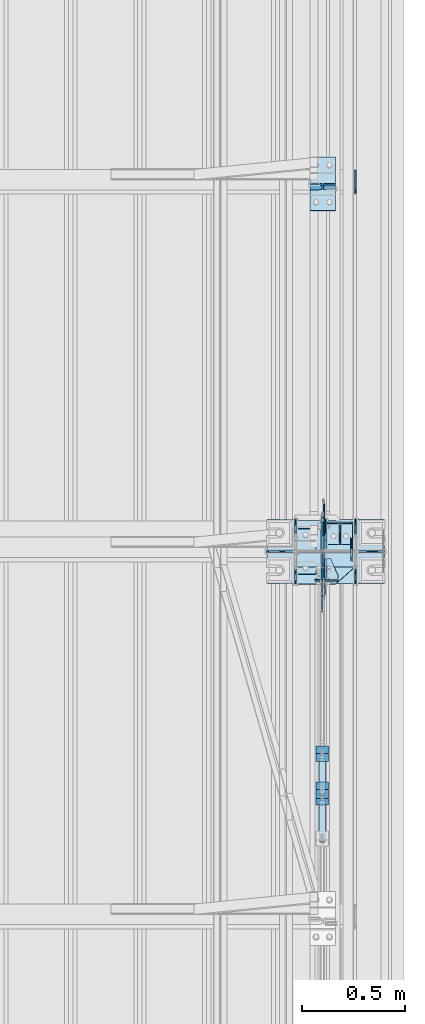
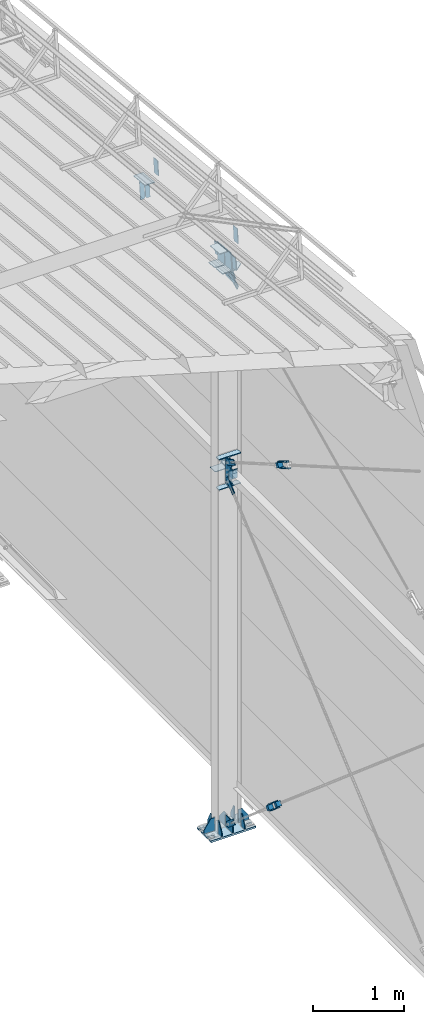
# One storey, part 166 of 709: 43 plates, 4 openings, 13 elements without a shape of their own.
"""IFC4 building model written with IfcOpenShell, lengths in millimetres."""

from ifc_helpers import new_model, si_unit, direction, frame, origin_with_axes, place, context, subcontext, project, spatial, line, arc, indexed_curve, outline, extrude, material, element, aggregate, save


model = new_model("IFC4")

# Units and contexts
model_context = context("Model", 3, precision=0.2, world=origin_with_axes(), true_north=direction((0.0, 1.0)))
body_context = subcontext(model_context, "Body", "Model", "MODEL_VIEW")
ifc_project = project(units=[si_unit("LENGTHUNIT", "METRE", prefix="MILLI"), si_unit("AREAUNIT", "SQUARE_METRE"), si_unit("VOLUMEUNIT", "CUBIC_METRE"), si_unit("MASSUNIT", "GRAM", prefix="KILO"), si_unit("TIMEUNIT", "SECOND"), si_unit("PLANEANGLEUNIT", "RADIAN"), si_unit("SOLIDANGLEUNIT", "STERADIAN"), si_unit("THERMODYNAMICTEMPERATUREUNIT", "DEGREE_CELSIUS"), si_unit("LUMINOUSINTENSITYUNIT", "LUMEN")], contexts=[model_context])

# Site, building, storey
site_placement = place(None, origin_with_axes())
site = spatial("IfcSite", under=ifc_project, at=site_placement, CompositionType="ELEMENT")
building_placement = place(site_placement, origin_with_axes())
building = spatial("IfcBuilding", under=site, at=building_placement, Name="Undefined", CompositionType="ELEMENT")
storey_placement = place(building_placement, origin_with_axes())
storey = spatial("IfcBuildingStorey", under=building, at=storey_placement, Name="Undefined", CompositionType="ELEMENT", Elevation=0.0)

# Assembly, plates
assembly_1_placement = place(storey_placement, frame((49837.5, 21654.0, 6929.907), z_axis=(-1.0, 0.0, 0.0), x_axis=(0.0, -0.9950371902, 0.099503719)))
assembly_1 = element("IfcElementAssembly", 1, at=assembly_1_placement, inside=storey)
ifc_material_1 = material(Name="C355-6", Category="STEEL")
plate_1_placement = place(assembly_1_placement, frame((3407.34474, 115.0, 62.0), z_axis=(-1.0, 0.0, 0.0), x_axis=(0.0, 0.0, -1.0)))
plate_1 = element("IfcPlate", 2, at=plate_1_placement, material=ifc_material_1, ObjectType="594", context=body_context, shape_type="SolidModel", body=[
    extrude(outline(indexed_curve([(0.0, 0.0), (43.5, 0.0), (58.5, 15.0), (58.5, 215.0), (43.5, 230.0), (0.0, 230.0)], segments=[line(1, 2, 3, 4, 5, 6, 1)])), frame((0.0, 0.0, 4.0), z_axis=(0.0, 0.0, 1.0), x_axis=(1.0, 0.0, 0.0)), (0.0, 0.0, -1.0), 8.0),
])
plate_2_placement = place(assembly_1_placement, frame((3407.34474, -115.0, -62.0), z_axis=(-1.0, 0.0, 0.0), x_axis=(0.0, 0.0, 1.0)))
plate_2 = element("IfcPlate", 3, at=plate_2_placement, material=ifc_material_1, ObjectType="594", context=body_context, shape_type="SolidModel", body=[
    extrude(outline(indexed_curve([(0.0, 0.0), (43.5, 0.0), (58.5, 15.0), (58.5, 215.0), (43.5, 230.0), (0.0, 230.0)], segments=[line(1, 2, 3, 4, 5, 6, 1)])), frame((0.0, 0.0, 4.0), z_axis=(0.0, 0.0, 1.0), x_axis=(1.0, 0.0, 0.0)), (0.0, 0.0, -1.0), 8.0),
])
plate_3_placement = place(assembly_1_placement, frame((5096.83432, -80.0, -6.5), z_axis=(0.0, 0.0, 1.0), x_axis=(0.0, 1.0, 0.0)))
plate_3 = element("IfcPlate", 4, at=plate_3_placement, material=ifc_material_1, ObjectType="463", context=body_context, shape_type="SolidModel", body=[
    extrude(outline(indexed_curve([(0.0, 0.0), (160.0, 0.0), (160.0, 160.0), (0.0, 160.0)], segments=[line(1, 2, 3, 4, 1)])), frame((0.0, 0.0, 4.0), z_axis=(0.0, 0.0, 1.0), x_axis=(1.0, 0.0, 0.0)), (0.0, 0.0, -1.0), 8.0),
])
aggregate(assembly_1, [plate_1, plate_2, plate_3])

# Assembly, plate
assembly_2_placement = place(storey_placement, frame((49837.5, 16500.0, 7445.307), z_axis=(-1.0, 0.0, 0.0), x_axis=(0.0, -0.9950371902, 0.099503719)))
assembly_2 = element("IfcElementAssembly", 5, at=assembly_2_placement, inside=storey)
plate_4_placement = place(assembly_2_placement, frame((66.87157, -80.0, -6.5), z_axis=(0.0, 0.0, -1.0), x_axis=(0.0, 1.0, 0.0)))
plate_4 = element("IfcPlate", 6, at=plate_4_placement, material=ifc_material_1, ObjectType="463", context=body_context, shape_type="SolidModel", body=[
    extrude(outline(indexed_curve([(0.0, 0.0), (160.0, 0.0), (160.0, 160.0), (0.0, 160.0)], segments=[line(1, 2, 3, 4, 1)])), frame((0.0, 0.0, 4.0), z_axis=(0.0, 0.0, 1.0), x_axis=(1.0, 0.0, 0.0)), (0.0, 0.0, -1.0), 8.0),
])
aggregate(assembly_2, [plate_4])

# Assembly, plates
assembly_3_placement = place(storey_placement, frame((49851.0, 11000.0, 4610.0), z_axis=(0.0, 0.0, -1.0), x_axis=(0.0, 1.0, 0.0)))
assembly_3 = element("IfcElementAssembly", 7, at=assembly_3_placement, inside=storey)
plate_5_placement = place(assembly_3_placement, frame((5361.5, -50.0, -60.0), z_axis=(1.0, 0.0, 0.0), x_axis=(0.0, 1.0, 0.0)))
plate_5 = element("IfcPlate", 8, at=plate_5_placement, material=ifc_material_1, ObjectType="519", context=body_context, shape_type="SolidModel", body=[
    extrude(outline(indexed_curve([(0.0, 0.0), (110.0, 0.0), (110.0, 120.0), (0.0, 120.0)], segments=[line(1, 2, 3, 4, 1)])), frame((0.0, 0.0, 4.0), z_axis=(0.0, 0.0, 1.0), x_axis=(1.0, 0.0, 0.0)), (0.0, 0.0, -1.0), 8.0),
])
plate_6_placement = place(assembly_3_placement, frame((5465.5, 0.0, -60.0), z_axis=(0.0, -1.0, 0.0), x_axis=(0.0, 0.0, 1.0)))
plate_6 = element("IfcPlate", 9, at=plate_6_placement, material=ifc_material_1, ObjectType="520", context=body_context, shape_type="SolidModel", body=[
    extrude(outline(indexed_curve([(0.0, 0.0), (120.0, 0.0), (120.0, 100.0), (0.0, 100.0)], segments=[line(1, 2, 3, 4, 1)])), frame((0.0, 0.0, 4.0), z_axis=(0.0, 0.0, 1.0), x_axis=(1.0, 0.0, 0.0)), (0.0, 0.0, -1.0), 8.0),
])
plate_7_placement = place(assembly_3_placement, frame((5465.5, 60.0, 0.0), z_axis=(0.0, 0.0, -1.0), x_axis=(0.0, -1.0, 0.0)))
plate_7 = element("IfcPlate", 10, at=plate_7_placement, material=ifc_material_1, ObjectType="521", context=body_context, shape_type="SolidModel", body=[
    extrude(outline(indexed_curve([(0.0, 80.0), (36.0, 0.0), (56.0, 0.0), (56.0, 90.0), (46.0, 100.0), (0.0, 100.0)], segments=[line(1, 2, 3, 4, 5, 6, 1)])), frame((0.0, 0.0, 4.0), z_axis=(0.0, 0.0, 1.0), x_axis=(1.0, 0.0, 0.0)), (0.0, 0.0, -1.0), 8.0),
])
aggregate(assembly_3, [plate_5, plate_6, plate_7])

# Assembly, plate
assembly_4_placement = place(storey_placement, frame((49835.0, 12064.45351, 754.36172), z_axis=(1.0, 0.0, 0.0), x_axis=(0.0, 0.7603239329, 0.649544084)))
assembly_4 = element("IfcElementAssembly", 11, at=assembly_4_placement, inside=storey)
plate_8_placement = place(assembly_4_placement, frame((5585.77433, 35.0, 0.0), z_axis=(0.0, 0.0, -1.0), x_axis=(1.0, 0.0, 0.0)))
plate_8 = element("IfcPlate", 12, at=plate_8_placement, material=ifc_material_1, ObjectType="525", context=body_context, shape_type="SolidModel", body=[
    extrude(outline(indexed_curve([(0.0, 0.0), (200.0, 0.0), (200.0, 70.0), (0.0, 70.0), (0.0, 46.0), (80.0, 46.0), (80.0, 24.0), (0.0, 24.0)], segments=[line(1, 2, 3, 4, 5, 6, 7, 8, 1)])), frame((0.0, 0.0, 4.0), z_axis=(0.0, 0.0, 1.0), x_axis=(1.0, 0.0, 0.0)), (0.0, 0.0, -1.0), 8.0),
])
aggregate(assembly_4, [plate_8])

assembly_5_placement = place(storey_placement, frame((49835.0, 15435.54649, 754.36172), z_axis=(1.0, 0.0, 0.0), x_axis=(0.0, 0.7603239329, -0.649544084)))
assembly_5 = element("IfcElementAssembly", 13, at=assembly_5_placement, inside=storey)
plate_9_placement = place(assembly_5_placement, frame((1140.17807, 11.0, 0.0), z_axis=(0.0, 0.0, 1.0), x_axis=(1.0, 0.0, 0.0)))
plate_9 = element("IfcPlate", 14, at=plate_9_placement, material=ifc_material_1, ObjectType="490", context=body_context, shape_type="SolidModel", body=[
    extrude(outline(indexed_curve([(0.0, 0.0), (80.0, 0.0), (80.0, -22.0), (0.0, -22.0), (0.0, -46.0), (200.0, -46.0), (200.0, 24.0), (0.0, 24.0)], segments=[line(1, 2, 3, 4, 5, 6, 7, 8, 1)])), frame((0.0, 0.0, 4.0), z_axis=(0.0, 0.0, 1.0), x_axis=(1.0, 0.0, 0.0)), (0.0, 0.0, -1.0), 8.0),
])
aggregate(assembly_5, [plate_9])

# Assembly, plates
assembly_6_placement = place(storey_placement, frame((49865.0, 15542.47007, 702.47387), z_axis=(0.0, -0.7603239329, 0.649544084), x_axis=(-1.0, 0.0, 0.0)))
assembly_6 = element("IfcElementAssembly", 15, at=assembly_6_placement, inside=storey)
ifc_material_2 = material(Name="Steel_Undefined", Category="STEEL")
plate_10_placement = place(assembly_6_placement, frame((0.0, 0.0, 230.0), z_axis=(0.0, 0.0, 1.0), x_axis=(1.0, 0.0, 0.0)))
plate_10 = element("IfcPlate", 16, at=plate_10_placement, material=ifc_material_2, ObjectType="483", context=body_context, shape_type="SolidModel", body=[
    extrude(outline(indexed_curve([(0.0, 0.0), (60.0, 0.0), (60.0, 60.0), (0.0, 60.0)], segments=[line(1, 2, 3, 4, 1)])), frame((0.0, 0.0, 25.0), z_axis=(0.0, 0.0, 1.0), x_axis=(1.0, 0.0, 0.0)), (0.0, 0.0, -1.0), 50.0),
])
plate_11_placement = place(assembly_6_placement, frame((15.0, 66.0, 230.0), z_axis=(0.0, 1.0, 0.0), x_axis=(1.0, 0.0, 0.0)))
plate_11 = element("IfcPlate", 17, at=plate_11_placement, material=ifc_material_2, ObjectType="484", context=body_context, shape_type="SolidModel", body=[
    extrude(outline(indexed_curve([(0.0, 0.0), (30.0, 0.0), (30.0, 230.0), (0.0, 230.0)], segments=[line(1, 2, 3, 4, 1)])), frame((0.0, 0.0, 6.0), z_axis=(0.0, 0.0, 1.0), x_axis=(1.0, 0.0, 0.0)), (0.0, 0.0, -1.0), 12.0),
])
plate_12_placement = place(assembly_6_placement, frame((15.0, -6.0, 230.0), z_axis=(0.0, 1.0, 0.0), x_axis=(1.0, 0.0, 0.0)))
plate_12 = element("IfcPlate", 18, at=plate_12_placement, material=ifc_material_2, ObjectType="484", context=body_context, shape_type="SolidModel", body=[
    extrude(outline(indexed_curve([(0.0, 0.0), (30.0, 0.0), (30.0, 230.0), (0.0, 230.0)], segments=[line(1, 2, 3, 4, 1)])), frame((0.0, 0.0, 6.0), z_axis=(0.0, 0.0, 1.0), x_axis=(1.0, 0.0, 0.0)), (0.0, 0.0, -1.0), 12.0),
])
plate_13_placement = place(assembly_6_placement, origin_with_axes())
plate_13 = element("IfcPlate", 19, at=plate_13_placement, material=ifc_material_2, ObjectType="482", context=body_context, shape_type="SolidModel", body=[
    extrude(outline(indexed_curve([(0.0, 0.0), (60.0, 0.0), (60.0, 60.0), (0.0, 60.0)], segments=[line(1, 2, 3, 4, 1)])), frame((0.0, 0.0, 25.0), z_axis=(0.0, 0.0, 1.0), x_axis=(1.0, 0.0, 0.0)), (0.0, 0.0, -1.0), 50.0),
])
aggregate(assembly_6, [plate_10, plate_11, plate_12, plate_13])

# Assembly, plate
assembly_7_placement = place(storey_placement, frame((49835.0, 12338.76537, 5341.35935), z_axis=(1.0, 0.0, 0.0), x_axis=(0.0, 0.9030466941, 0.429542394)))
assembly_7 = element("IfcElementAssembly", 20, at=assembly_7_placement, inside=storey)
plate_14_placement = place(assembly_7_placement, frame((4300.24452, -11.0, 0.0), z_axis=(0.0, 0.0, -1.0), x_axis=(1.0, 0.0, 0.0)))
plate_14 = element("IfcPlate", 21, at=plate_14_placement, material=ifc_material_1, ObjectType="490", context=body_context, shape_type="SolidModel", body=[
    extrude(outline(indexed_curve([(0.0, 0.0), (80.0, 0.0), (80.0, -22.0), (0.0, -22.0), (0.0, -46.0), (200.0, -46.0), (200.0, 24.0), (0.0, 24.0)], segments=[line(1, 2, 3, 4, 5, 6, 7, 8, 1)])), frame((0.0, 0.0, 4.0), z_axis=(0.0, 0.0, 1.0), x_axis=(1.0, 0.0, 0.0)), (0.0, 0.0, -1.0), 8.0),
])
aggregate(assembly_7, [plate_14])

assembly_8_placement = place(storey_placement, frame((49835.0, 15212.89749, 5439.71077), z_axis=(1.0, 0.0, 0.0), x_axis=(0.0, 0.866144648, -0.499793406)))
assembly_8 = element("IfcElementAssembly", 22, at=assembly_8_placement, inside=storey)
plate_15_placement = place(assembly_8_placement, frame((1250.0, 35.0, 0.0), z_axis=(0.0, 0.0, -1.0), x_axis=(1.0, 0.0, 0.0)))
plate_15 = element("IfcPlate", 23, at=plate_15_placement, material=ifc_material_1, ObjectType="525", context=body_context, shape_type="SolidModel", body=[
    extrude(outline(indexed_curve([(0.0, 0.0), (200.0, 0.0), (200.0, 70.0), (0.0, 70.0), (0.0, 46.0), (80.0, 46.0), (80.0, 24.0), (0.0, 24.0)], segments=[line(1, 2, 3, 4, 5, 6, 7, 8, 1)])), frame((0.0, 0.0, 4.0), z_axis=(0.0, 0.0, 1.0), x_axis=(1.0, 0.0, 0.0)), (0.0, 0.0, -1.0), 8.0),
])
aggregate(assembly_8, [plate_15])

# Assembly, plates
assembly_9_placement = place(storey_placement, frame((49865.0, 15327.49793, 5408.21887), z_axis=(0.0, -0.866144648, 0.499793406), x_axis=(-1.0, 0.0, 0.0)))
assembly_9 = element("IfcElementAssembly", 24, at=assembly_9_placement, inside=storey)
plate_16_placement = place(assembly_9_placement, frame((15.0, -6.0, 230.0), z_axis=(0.0, 1.0, 0.0), x_axis=(1.0, 0.0, 0.0)))
plate_16 = element("IfcPlate", 25, at=plate_16_placement, material=ifc_material_2, ObjectType="484", context=body_context, shape_type="SolidModel", body=[
    extrude(outline(indexed_curve([(0.0, 0.0), (30.0, 0.0), (30.0, 230.0), (0.0, 230.0)], segments=[line(1, 2, 3, 4, 1)])), frame((0.0, 0.0, 6.0), z_axis=(0.0, 0.0, 1.0), x_axis=(1.0, 0.0, 0.0)), (0.0, 0.0, -1.0), 12.0),
])
plate_17_placement = place(assembly_9_placement, origin_with_axes())
plate_17 = element("IfcPlate", 26, at=plate_17_placement, material=ifc_material_2, ObjectType="482", context=body_context, shape_type="SolidModel", body=[
    extrude(outline(indexed_curve([(0.0, 0.0), (60.0, 0.0), (60.0, 60.0), (0.0, 60.0)], segments=[line(1, 2, 3, 4, 1)])), frame((0.0, 0.0, 25.0), z_axis=(0.0, 0.0, 1.0), x_axis=(1.0, 0.0, 0.0)), (0.0, 0.0, -1.0), 50.0),
])
plate_18_placement = place(assembly_9_placement, frame((15.0, 66.0, 230.0), z_axis=(0.0, 1.0, 0.0), x_axis=(1.0, 0.0, 0.0)))
plate_18 = element("IfcPlate", 27, at=plate_18_placement, material=ifc_material_2, ObjectType="484", context=body_context, shape_type="SolidModel", body=[
    extrude(outline(indexed_curve([(0.0, 0.0), (30.0, 0.0), (30.0, 230.0), (0.0, 230.0)], segments=[line(1, 2, 3, 4, 1)])), frame((0.0, 0.0, 6.0), z_axis=(0.0, 0.0, 1.0), x_axis=(1.0, 0.0, 0.0)), (0.0, 0.0, -1.0), 12.0),
])
aggregate(assembly_9, [plate_16, plate_17, plate_18])

# Assembly, plates, voiding features
assembly_10_placement = place(storey_placement, frame((49851.0, 16500.0, -200.0), z_axis=(0.0, -1.0, 0.0), x_axis=(0.0, 0.0, 1.0)))
assembly_10 = element("IfcElementAssembly", 28, at=assembly_10_placement, inside=storey)
plate_19_placement = place(assembly_10_placement, frame((7533.41354, 17.0, -2.75), z_axis=(0.0, -1.0, 0.0), x_axis=(-0.099503719, 0.0, -0.9950371902)))
plate_19 = element("IfcPlate", 29, at=plate_19_placement, material=ifc_material_1, ObjectType="477", context=body_context, shape_type="SolidModel", body=[
    extrude(outline(indexed_curve([(0.0, 0.0), (147.70786, 0.0), (150.29495, 222.12903), (-22.97066, 222.06948)], segments=[line(1, 2, 3, 4, 1)])), frame((0.0, 0.0, 6.0), z_axis=(0.0, 0.0, 1.0), x_axis=(1.0, 0.0, 0.0)), (0.0, 0.0, -1.0), 12.0),
])
plate_20_placement = place(assembly_10_placement, frame((7526.28426, 139.0, -4.34206), z_axis=(-0.9950371902, 0.0, 0.099503719), x_axis=(-0.099503719, 0.0, -0.9950371902)))
plate_20 = element("IfcPlate", 30, at=plate_20_placement, material=ifc_material_1, ObjectType="476", context=body_context, shape_type="SolidModel", body=[
    extrude(outline(indexed_curve([(-0.10791, 14.99961), (15.0, 0.0), (146.70786, 0.0), (146.70786, 187.5), (71.5, 278.0), (13.0, 278.0), (-1.89209, 263.00039)], segments=[line(1, 2, 3, 4, 5, 6, 7, 1)])), frame((0.0, 0.0, 6.0), z_axis=(0.0, 0.0, 1.0), x_axis=(1.0, 0.0, 0.0)), (0.0, 0.0, -1.0), 12.0),
])
plate_21_placement = place(assembly_10_placement, frame((7527.03327, 139.0, 3.14801), z_axis=(0.9950371902, 0.0, -0.099503719), x_axis=(0.099503719, 0.0, 0.9950371902)))
plate_21 = element("IfcPlate", 31, at=plate_21_placement, material=ifc_material_1, ObjectType="474", context=body_context, shape_type="SolidModel", body=[
    extrude(outline(indexed_curve([(0.0, 15.0), (15.0, 0.0), (155.50786, 0.0), (155.50786, 187.5), (73.5, 278.0), (15.0, 278.0), (0.0, 263.0)], segments=[line(1, 2, 3, 4, 5, 6, 7, 1)])), frame((0.0, 0.0, 6.0), z_axis=(0.0, 0.0, 1.0), x_axis=(1.0, 0.0, 0.0)), (0.0, 0.0, -1.0), 12.0),
])
plate_22_placement = place(assembly_10_placement, frame((7534.16255, 17.0, 4.74007), z_axis=(0.0, 1.0, 0.0), x_axis=(0.099503719, 0.0, 0.9950371902)))
plate_22 = element("IfcPlate", 32, at=plate_22_placement, material=ifc_material_1, ObjectType="475", context=body_context, shape_type="SolidModel", body=[
    extrude(outline(indexed_curve([(0.0, 0.0), (154.50786, 0.0), (151.92076, 222.12903), (19.44323, 222.06948)], segments=[line(1, 2, 3, 4, 1)])), frame((0.0, 0.0, 6.0), z_axis=(0.0, 0.0, 1.0), x_axis=(1.0, 0.0, 0.0)), (0.0, 0.0, -1.0), 12.0),
])
plate_23_placement = place(assembly_10_placement, frame((25.0, 0.0, -2.75), z_axis=(0.0, -1.0, 0.0), x_axis=(0.0, 0.0, -1.0)))
plate_23 = element("IfcPlate", 33, at=plate_23_placement, material=ifc_material_1, ObjectType="417", context=body_context, shape_type="SolidModel", body=[
    extrude(outline(indexed_curve([(0.0, 0.0), (152.25, 0.0), (152.25, 50.0), (50.0, 175.0), (0.0, 175.0)], segments=[line(1, 2, 3, 4, 5, 1)])), frame((0.0, 0.0, 4.0), z_axis=(0.0, 0.0, 1.0), x_axis=(1.0, 0.0, 0.0)), (0.0, 0.0, -1.0), 8.0),
])
plate_24_placement = place(assembly_10_placement, frame((12.5, -284.0, 155.0), z_axis=(1.0, 0.0, 0.0), x_axis=(0.0, 0.0, -1.0)))
plate_24 = element("IfcPlate", 34, at=plate_24_placement, material=ifc_material_1, context=body_context, shape_type="SolidModel", body=[
    extrude(outline(indexed_curve([(0.0, 0.0), (310.0, 0.0), (310.0, 568.0), (0.0, 568.0)], segments=[line(1, 2, 3, 4, 1)])), frame((0.0, 0.0, 12.5), z_axis=(0.0, 0.0, 1.0), x_axis=(1.0, 0.0, 0.0)), (0.0, 0.0, -1.0), 25.0),
])
voiding_feature_1_placement = place(plate_24_placement, frame((40.0, 568.0, 0.0), z_axis=(0.0, 0.0, -1.0), x_axis=(1.0, 0.0, 0.0)))
element("IfcVoidingFeature", 35, at=voiding_feature_1_placement, cuts=plate_24, PredefinedType="HOLE", context=body_context, shape_type="SolidModel", body=[
    extrude(outline(indexed_curve([(0.0, 0.0), (50.0, 0.0), (50.0, 60.0), (42.67767, 77.67767), (25.0, 85.0), (25.0, 85.0), (7.32233, 77.67767), (0.0, 60.0)], segments=[line(1, 2, 3), arc(3, 4, 5), line(5, 6), arc(6, 7, 8), line(8, 1)])), frame((0.0, 0.0, 12.5), z_axis=(0.0, 0.0, 1.0), x_axis=(1.0, 0.0, 0.0)), (0.0, 0.0, -1.0), 25.0),
])
voiding_feature_2_placement = place(plate_24_placement, frame((40.0, 0.0, 0.0), z_axis=(0.0, 0.0, 1.0), x_axis=(1.0, 0.0, 0.0)))
element("IfcVoidingFeature", 36, at=voiding_feature_2_placement, cuts=plate_24, PredefinedType="HOLE", context=body_context, shape_type="SolidModel", body=[
    extrude(outline(indexed_curve([(0.0, 0.0), (50.0, 0.0), (50.0, 60.0), (42.67767, 77.67767), (25.0, 85.0), (25.0, 85.0), (7.32233, 77.67767), (0.0, 60.0)], segments=[line(1, 2, 3), arc(3, 4, 5), line(5, 6), arc(6, 7, 8), line(8, 1)])), frame((0.0, 0.0, 12.5), z_axis=(0.0, 0.0, 1.0), x_axis=(1.0, 0.0, 0.0)), (0.0, 0.0, -1.0), 25.0),
])
voiding_feature_3_placement = place(plate_24_placement, frame((270.0, 568.0, 0.0), z_axis=(0.0, 0.0, 1.0), x_axis=(-1.0, 0.0, 0.0)))
element("IfcVoidingFeature", 37, at=voiding_feature_3_placement, cuts=plate_24, PredefinedType="HOLE", context=body_context, shape_type="SolidModel", body=[
    extrude(outline(indexed_curve([(0.0, 0.0), (50.0, 0.0), (50.0, 60.0), (42.67767, 77.67767), (25.0, 85.0), (25.0, 85.0), (7.32233, 77.67767), (0.0, 60.0)], segments=[line(1, 2, 3), arc(3, 4, 5), line(5, 6), arc(6, 7, 8), line(8, 1)])), frame((0.0, 0.0, 12.5), z_axis=(0.0, 0.0, 1.0), x_axis=(1.0, 0.0, 0.0)), (0.0, 0.0, -1.0), 25.0),
])
voiding_feature_4_placement = place(plate_24_placement, frame((270.0, 0.0, 0.0), z_axis=(0.0, 0.0, -1.0), x_axis=(-1.0, 0.0, 0.0)))
element("IfcVoidingFeature", 38, at=voiding_feature_4_placement, cuts=plate_24, PredefinedType="HOLE", context=body_context, shape_type="SolidModel", body=[
    extrude(outline(indexed_curve([(0.0, 0.0), (50.0, 0.0), (50.0, 60.0), (42.67767, 77.67767), (25.0, 85.0), (25.0, 85.0), (7.32233, 77.67767), (0.0, 60.0)], segments=[line(1, 2, 3), arc(3, 4, 5), line(5, 6), arc(6, 7, 8), line(8, 1)])), frame((0.0, 0.0, 12.5), z_axis=(0.0, 0.0, 1.0), x_axis=(1.0, 0.0, 0.0)), (0.0, 0.0, -1.0), 25.0),
])
plate_25_placement = place(assembly_10_placement, frame((25.0, 149.0, 0.0), z_axis=(0.0, 0.0, -1.0), x_axis=(0.0, 1.0, 0.0)))
plate_25 = element("IfcPlate", 39, at=plate_25_placement, material=ifc_material_1, ObjectType="418", context=body_context, shape_type="SolidModel", body=[
    extrude(outline(indexed_curve([(0.0, 0.0), (135.0, 0.0), (135.0, 50.0), (50.0, 175.0), (0.0, 175.0)], segments=[line(1, 2, 3, 4, 5, 1)])), frame((0.0, 0.0, 4.0), z_axis=(0.0, 0.0, 1.0), x_axis=(1.0, 0.0, 0.0)), (0.0, 0.0, -1.0), 8.0),
])
plate_26_placement = place(assembly_10_placement, frame((25.0, -145.0, 74.5), z_axis=(0.0, 1.0, 0.0), x_axis=(0.0, 0.0, 1.0)))
plate_26 = element("IfcPlate", 40, at=plate_26_placement, material=ifc_material_1, ObjectType="426", context=body_context, shape_type="SolidModel", body=[
    extrude(outline(indexed_curve([(0.0, 0.0), (80.5, 0.0), (80.5, 50.0), (20.0, 175.0), (0.0, 175.0)], segments=[line(1, 2, 3, 4, 5, 1)])), frame((0.0, 0.0, 4.0), z_axis=(0.0, 0.0, 1.0), x_axis=(1.0, 0.0, 0.0)), (0.0, 0.0, -1.0), 8.0),
])
plate_27_placement = place(assembly_10_placement, frame((25.0, 145.0, 74.5), z_axis=(0.0, 1.0, 0.0), x_axis=(0.0, 0.0, 1.0)))
plate_27 = element("IfcPlate", 41, at=plate_27_placement, material=ifc_material_1, ObjectType="426", context=body_context, shape_type="SolidModel", body=[
    extrude(outline(indexed_curve([(0.0, 0.0), (80.5, 0.0), (80.5, 50.0), (20.0, 175.0), (0.0, 175.0)], segments=[line(1, 2, 3, 4, 5, 1)])), frame((0.0, 0.0, 4.0), z_axis=(0.0, 0.0, 1.0), x_axis=(1.0, 0.0, 0.0)), (0.0, 0.0, -1.0), 8.0),
])
plate_28_placement = place(assembly_10_placement, frame((25.0, 145.0, -74.5), z_axis=(0.0, -1.0, 0.0), x_axis=(0.0, 0.0, -1.0)))
plate_28 = element("IfcPlate", 42, at=plate_28_placement, material=ifc_material_1, ObjectType="426", context=body_context, shape_type="SolidModel", body=[
    extrude(outline(indexed_curve([(0.0, 0.0), (80.5, 0.0), (80.5, 50.0), (20.0, 175.0), (0.0, 175.0)], segments=[line(1, 2, 3, 4, 5, 1)])), frame((0.0, 0.0, 4.0), z_axis=(0.0, 0.0, 1.0), x_axis=(1.0, 0.0, 0.0)), (0.0, 0.0, -1.0), 8.0),
])
plate_29_placement = place(assembly_10_placement, frame((25.0, -145.0, -74.5), z_axis=(0.0, -1.0, 0.0), x_axis=(0.0, 0.0, -1.0)))
plate_29 = element("IfcPlate", 43, at=plate_29_placement, material=ifc_material_1, ObjectType="426", context=body_context, shape_type="SolidModel", body=[
    extrude(outline(indexed_curve([(0.0, 0.0), (80.5, 0.0), (80.5, 50.0), (20.0, 175.0), (0.0, 175.0)], segments=[line(1, 2, 3, 4, 5, 1)])), frame((0.0, 0.0, 4.0), z_axis=(0.0, 0.0, 1.0), x_axis=(1.0, 0.0, 0.0)), (0.0, 0.0, -1.0), 8.0),
])
plate_30_placement = place(assembly_10_placement, frame((25.0, -149.0, 0.0), z_axis=(0.0, 0.0, 1.0), x_axis=(0.0, -1.0, 0.0)))
plate_30 = element("IfcPlate", 44, at=plate_30_placement, material=ifc_material_1, ObjectType="418", context=body_context, shape_type="SolidModel", body=[
    extrude(outline(indexed_curve([(0.0, 0.0), (135.0, 0.0), (135.0, 50.0), (50.0, 175.0), (0.0, 175.0)], segments=[line(1, 2, 3, 4, 5, 1)])), frame((0.0, 0.0, 4.0), z_axis=(0.0, 0.0, 1.0), x_axis=(1.0, 0.0, 0.0)), (0.0, 0.0, -1.0), 8.0),
])
plate_31_placement = place(assembly_10_placement, frame((114.59681, 6.0, 150.74592), z_axis=(0.0, 1.0, 0.0), x_axis=(0.7603239329, 0.0, -0.649544084)))
plate_31 = element("IfcPlate", 45, at=plate_31_placement, material=ifc_material_1, ObjectType="518", context=body_context, shape_type="SolidModel", body=[
    extrude(outline(indexed_curve([(0.0, 0.0), (90.0, 0.0), (148.1582, 68.07709), (39.41213, 160.97876), (18.26411, 159.31706), (-68.1226, 58.19708)], segments=[line(1, 2, 3, 4, 5, 6, 1)])), frame((0.0, 0.0, 6.0), z_axis=(0.0, 0.0, 1.0), x_axis=(1.0, 0.0, 0.0)), (0.0, 0.0, -1.0), 12.0),
])
plate_32_placement = place(assembly_10_placement, frame((5003.96618, 10.0, 95.31653), z_axis=(0.0, -1.0, 0.0), x_axis=(-0.866144648, 0.0, 0.499793406)))
plate_32 = element("IfcPlate", 46, at=plate_32_placement, material=ifc_material_1, ObjectType="522", context=body_context, shape_type="SolidModel", body=[
    extrude(outline(indexed_curve([(0.0, 0.0), (90.0, 0.0), (116.96042, 45.34182), (238.22067, 115.3129), (302.30174, 120.83347), (332.35388, 205.66783), (299.59906, 262.43211), (279.10999, 267.92738), (-33.27197, 87.6729), (-38.76724, 67.18383)], segments=[line(1, 2, 3, 4, 5, 6, 7, 8, 9, 10, 1)])), frame((0.0, 0.0, 6.0), z_axis=(0.0, 0.0, 1.0), x_axis=(1.0, 0.0, 0.0)), (0.0, 0.0, -1.0), 12.0),
])
plate_33_placement = place(assembly_10_placement, frame((5009.96618, 140.0, 74.5), z_axis=(-1.0, 0.0, 0.0), x_axis=(0.0, 0.0, -1.0)))
plate_33 = element("IfcPlate", 47, at=plate_33_placement, material=ifc_material_1, ObjectType="523", context=body_context, shape_type="SolidModel", body=[
    extrude(outline(indexed_curve([(0.0, 0.0), (55.75, 0.0), (70.75, 15.0), (70.75, 265.0), (55.75, 280.0), (0.0, 280.0)], segments=[line(1, 2, 3, 4, 5, 6, 1)])), frame((0.0, 0.0, 6.0), z_axis=(0.0, 0.0, 1.0), x_axis=(1.0, 0.0, 0.0)), (0.0, 0.0, -1.0), 12.0),
])
plate_34_placement = place(assembly_10_placement, frame((4607.30822, 140.0, 74.5), z_axis=(-1.0, 0.0, 0.0), x_axis=(0.0, 0.0, -1.0)))
plate_34 = element("IfcPlate", 48, at=plate_34_placement, material=ifc_material_1, ObjectType="524", context=body_context, shape_type="SolidModel", body=[
    extrude(outline(indexed_curve([(0.0, 0.0), (55.75, 0.0), (70.75, 15.0), (70.75, 265.0), (55.75, 280.0), (0.0, 280.0)], segments=[line(1, 2, 3, 4, 5, 6, 1)])), frame((0.0, 0.0, 4.0), z_axis=(0.0, 0.0, 1.0), x_axis=(1.0, 0.0, 0.0)), (0.0, 0.0, -1.0), 8.0),
])
plate_35_placement = place(assembly_10_placement, frame((7472.08802, 6.0, 206.93777), z_axis=(0.0, -1.0, 0.0), x_axis=(-0.9030466941, 0.0, -0.429542394)))
plate_35 = element("IfcPlate", 49, at=plate_35_placement, material=ifc_material_1, ObjectType="527", context=body_context, shape_type="SolidModel", body=[
    extrude(outline(indexed_curve([(0.0, 0.0), (90.0, 0.0), (161.1017, 149.48037), (57.11612, 198.94206), (35.81141, 192.54783), (-37.38595, 71.44202)], segments=[line(1, 2, 3, 4, 5, 6, 1)])), frame((0.0, 0.0, 6.0), z_axis=(0.0, 0.0, 1.0), x_axis=(1.0, 0.0, 0.0)), (0.0, 0.0, -1.0), 12.0),
])
plate_36_placement = place(assembly_10_placement, frame((4802.0, -140.0, -114.5), z_axis=(-1.0, 0.0, 0.0), x_axis=(0.0, 0.0, 1.0)))
plate_36 = element("IfcPlate", 50, at=plate_36_placement, material=ifc_material_1, ObjectType="505", context=body_context, shape_type="SolidModel", body=[
    extrude(outline(indexed_curve([(0.0, 0.0), (95.75, 0.0), (110.75, 15.0), (110.75, 265.0), (95.75, 280.0), (0.0, 280.0)], segments=[line(1, 2, 3, 4, 5, 6, 1)])), frame((0.0, 0.0, 4.0), z_axis=(0.0, 0.0, 1.0), x_axis=(1.0, 0.0, 0.0)), (0.0, 0.0, -1.0), 8.0),
])
aggregate(assembly_10, [plate_19, plate_20, plate_21, plate_22, plate_23, plate_24, plate_25, plate_26, plate_27, plate_28, plate_29, plate_30, plate_31, plate_32, plate_33, plate_34, plate_35, plate_36])

# Assembly, plates
assembly_11_placement = place(storey_placement, frame((49920.0, 16500.0, 4610.0), z_axis=(0.0, 0.0, -1.0), x_axis=(0.0, 1.0, 0.0)))
assembly_11 = element("IfcElementAssembly", 51, at=assembly_11_placement, inside=storey)
plate_37_placement = place(assembly_11_placement, frame((34.5, 0.0, -60.0), z_axis=(0.0, 1.0, 0.0), x_axis=(0.0, 0.0, 1.0)))
plate_37 = element("IfcPlate", 52, at=plate_37_placement, material=ifc_material_1, ObjectType="508", context=body_context, shape_type="SolidModel", body=[
    extrude(outline(indexed_curve([(0.0, 80.0), (36.0, 0.0), (56.0, 0.0), (56.0, 90.0), (46.0, 100.0), (0.0, 100.0)], segments=[line(1, 2, 3, 4, 5, 6, 1)])), frame((0.0, 0.0, 4.0), z_axis=(0.0, 0.0, 1.0), x_axis=(1.0, 0.0, 0.0)), (0.0, 0.0, -1.0), 8.0),
])
plate_38_placement = place(assembly_11_placement, frame((138.5, 60.0, 60.0), z_axis=(-1.0, 0.0, 0.0), x_axis=(0.0, 0.0, -1.0)))
plate_38 = element("IfcPlate", 53, at=plate_38_placement, material=ifc_material_1, ObjectType="506", context=body_context, shape_type="SolidModel", body=[
    extrude(outline(indexed_curve([(0.0, 0.0), (120.0, 0.0), (120.0, 120.0), (0.0, 120.0)], segments=[line(1, 2, 3, 4, 1)])), frame((0.0, 0.0, 4.0), z_axis=(0.0, 0.0, 1.0), x_axis=(1.0, 0.0, 0.0)), (0.0, 0.0, -1.0), 8.0),
])
plate_39_placement = place(assembly_11_placement, frame((34.5, 60.0, 0.0), z_axis=(0.0, 0.0, 1.0), x_axis=(0.0, -1.0, 0.0)))
plate_39 = element("IfcPlate", 54, at=plate_39_placement, material=ifc_material_1, ObjectType="507", context=body_context, shape_type="SolidModel", body=[
    extrude(outline(indexed_curve([(0.0, 0.0), (120.0, 0.0), (120.0, 100.0), (0.0, 100.0)], segments=[line(1, 2, 3, 4, 1)])), frame((0.0, 0.0, 4.0), z_axis=(0.0, 0.0, 1.0), x_axis=(1.0, 0.0, 0.0)), (0.0, 0.0, -1.0), 8.0),
])
aggregate(assembly_11, [plate_37, plate_38, plate_39])

assembly_12_placement = place(storey_placement, frame((50000.0, 16509.95037, 7677.46908), z_axis=(0.0, -0.9950371902, 0.099503719), x_axis=(-1.0, 0.0, 0.0)))
assembly_12 = element("IfcElementAssembly", 55, at=assembly_12_placement, inside=storey)
plate_40_placement = place(assembly_12_placement, frame((24.0, 97.0, 47.0), z_axis=(-1.0, 0.0, 0.0), x_axis=(0.0, 0.0, -1.0)))
plate_40 = element("IfcPlate", 56, at=plate_40_placement, material=ifc_material_1, ObjectType="592", context=body_context, shape_type="SolidModel", body=[
    extrude(outline(indexed_curve([(0.0, 0.0), (94.0, 0.0), (94.0, 194.0), (0.0, 194.0)], segments=[line(1, 2, 3, 4, 1)])), frame((0.0, 0.0, 4.0), z_axis=(0.0, 0.0, 1.0), x_axis=(1.0, 0.0, 0.0)), (0.0, 0.0, -1.0), 8.0),
])
plate_41_placement = place(assembly_12_placement, frame((196.0, 103.94045, -110.0), z_axis=(0.0, -1.0, 0.0), x_axis=(1.0, 0.0, 0.0)))
plate_41 = element("IfcPlate", 57, at=plate_41_placement, material=ifc_material_1, ObjectType="591", context=body_context, shape_type="SolidModel", body=[
    extrude(outline(indexed_curve([(0.0, 0.0), (100.0, 0.0), (100.0, 220.0), (0.0, 220.0)], segments=[line(1, 2, 3, 4, 1)])), frame((0.0, 0.0, 4.0), z_axis=(0.0, 0.0, 1.0), x_axis=(1.0, 0.0, 0.0)), (0.0, 0.0, -1.0), 8.0),
])
aggregate(assembly_12, [plate_40, plate_41])

assembly_13_placement = place(storey_placement, frame((50000.0, 18286.65012, 7499.7991), z_axis=(0.0, -0.9950371902, 0.099503719), x_axis=(-1.0, 0.0, 0.0)))
assembly_13 = element("IfcElementAssembly", 58, at=assembly_13_placement, inside=storey)
plate_42_placement = place(assembly_13_placement, frame((4.0, 97.0, 47.0), z_axis=(-1.0, 0.0, 0.0), x_axis=(0.0, 0.0, -1.0)))
plate_42 = element("IfcPlate", 59, at=plate_42_placement, material=ifc_material_1, ObjectType="592", context=body_context, shape_type="SolidModel", body=[
    extrude(outline(indexed_curve([(0.0, 0.0), (94.0, 0.0), (94.0, 194.0), (0.0, 194.0)], segments=[line(1, 2, 3, 4, 1)])), frame((0.0, 0.0, 4.0), z_axis=(0.0, 0.0, 1.0), x_axis=(1.0, 0.0, 0.0)), (0.0, 0.0, -1.0), 8.0),
])
plate_43_placement = place(assembly_13_placement, frame((100.5, 104.0, -130.0), z_axis=(0.0, 1.0, 0.0), x_axis=(0.0, 0.0, 1.0)))
plate_43 = element("IfcPlate", 60, at=plate_43_placement, material=ifc_material_1, ObjectType="593", context=body_context, shape_type="SolidModel", body=[
    extrude(outline(indexed_curve([(0.0, 0.0), (260.0, 0.0), (260.0, 124.0), (0.0, 124.0)], segments=[line(1, 2, 3, 4, 1)])), frame((0.0, 0.0, 4.0), z_axis=(0.0, 0.0, 1.0), x_axis=(1.0, 0.0, 0.0)), (0.0, 0.0, -1.0), 8.0),
])
aggregate(assembly_13, [plate_42, plate_43])

save(model, "model.ifc")
